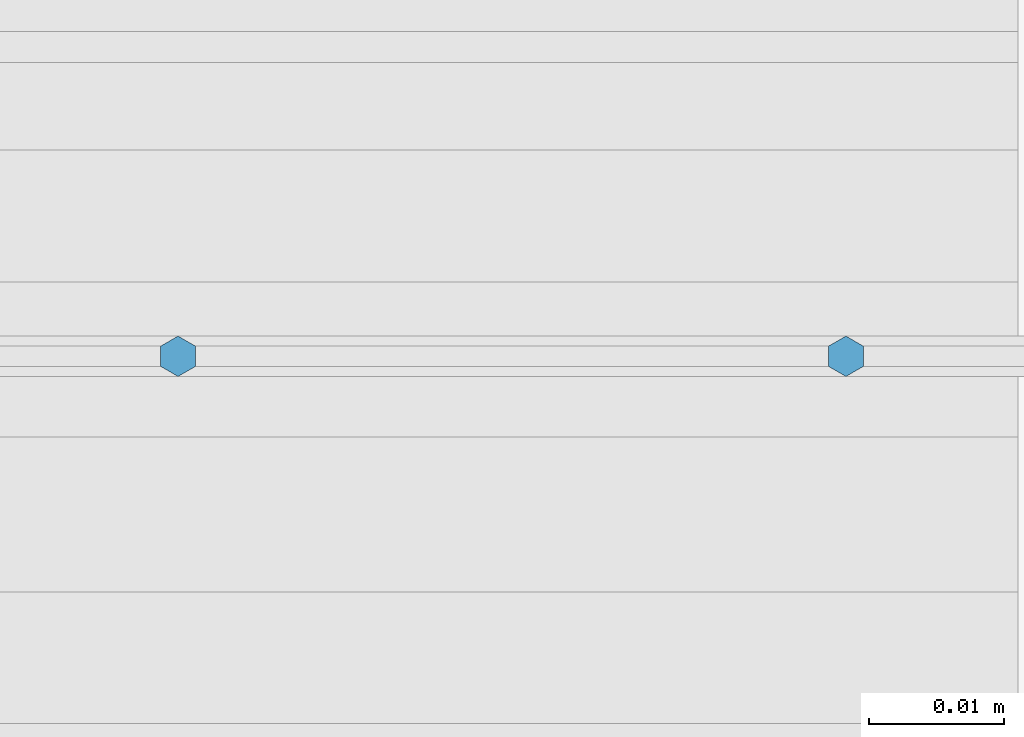
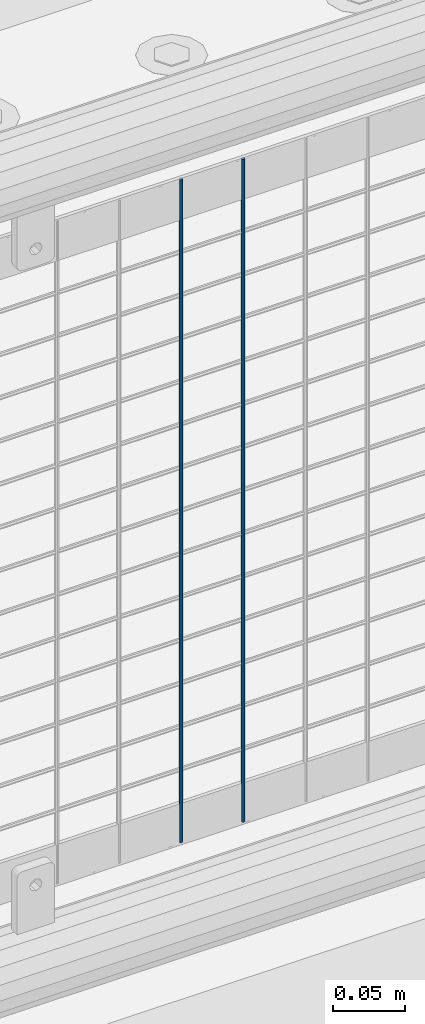
# One storey, part 66 of 208: 2 columns.
"""IFC2X3 building model written with IfcOpenShell, lengths in millimetres."""

from ifc_helpers import new_model, si_unit, frame, origin_with_axes, place, context, subcontext, project, spatial, faceted_brep, material, type_object, element, save


model = new_model("IFC2X3")

# Units and contexts
model_context = context("Model", 3, precision=1e-05, world=origin_with_axes())
body_context = subcontext(model_context, "Body", "Model", "MODEL_VIEW")
ifc_project = project(units=[si_unit("LENGTHUNIT", "METRE", prefix="MILLI"), si_unit("AREAUNIT", "SQUARE_METRE"), si_unit("VOLUMEUNIT", "CUBIC_METRE"), si_unit("MASSUNIT", "GRAM", prefix="KILO"), si_unit("TIMEUNIT", "SECOND"), si_unit("PLANEANGLEUNIT", "RADIAN"), si_unit("SOLIDANGLEUNIT", "STERADIAN"), si_unit("THERMODYNAMICTEMPERATUREUNIT", "DEGREE_CELSIUS"), si_unit("LUMINOUSINTENSITYUNIT", "LUMEN")], contexts=[model_context])

# Site, building, storey
site_placement = place(None, origin_with_axes())
site = spatial("IfcSite", under=ifc_project, at=site_placement, CompositionType="ELEMENT")
building_placement = place(site_placement, origin_with_axes())
building = spatial("IfcBuilding", under=site, at=building_placement, Name="Standard", CompositionType="ELEMENT")
storey_placement = place(building_placement, origin_with_axes())
storey = spatial("IfcBuildingStorey", under=building, at=storey_placement, Name="Undefined", CompositionType="ELEMENT", Elevation=0.0)

# Columns
ifc_material = material(Name="Misc_Undefined")
column_type = type_object("IfcColumnType", Name="D3", PredefinedType="NOTDEFINED")
for number, where, z_axis, x_axis in (
    (1, (-36402.795, 4670.5, 353.020000000001), (-1.0, 0.0, 0.0), (0.0, 0.0, 1.0)),
    (2, (-36452.45, 4670.5, 353.020000000001), (-1.0, 0.0, 0.0), (0.0, 0.0, 1.0)),
):
    element("IfcColumn", number, at=place(storey_placement, frame(where, z_axis=z_axis, x_axis=x_axis)), inside=storey, type_object=column_type, material=ifc_material, ObjectType="D3", context=body_context, shape_type="Brep", body=[
        faceted_brep([(0.0, -1.49999999999909, 3.63797880709171e-12), (-7.27595761418343e-12, -0.749999999999091, -1.29903810567669), (560.0, -0.75, -1.29903810567703), (560.0, -1.5, 0.0), (-3.63797880709171e-12, 0.750000000000909, -1.29903810567669), (560.0, 0.75, -1.29903810567703), (0.0, 1.50000000000182, 3.63797880709171e-12), (560.0, 1.5, 0.0), (-3.63797880709171e-12, 0.750000000000909, 1.29903810567669), (560.0, 0.75, 1.29903810567703), (-7.27595761418343e-12, -0.749999999999091, 1.29903810567669), (560.0, -0.75, 1.29903810567703)], [[[0, 1, 2, 3]], [[1, 4, 5, 2]], [[4, 6, 7, 5]], [[6, 8, 9, 7]], [[8, 10, 11, 9]], [[10, 0, 3, 11]], [[5, 7, 9, 11, 3, 2]], [[10, 8, 6, 4, 1, 0]]]),
    ])

save(model, "model.ifc")
